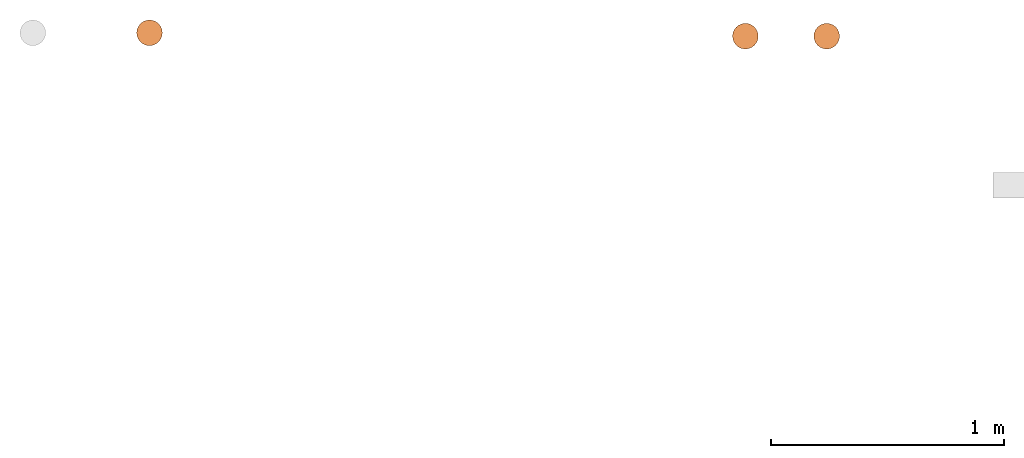
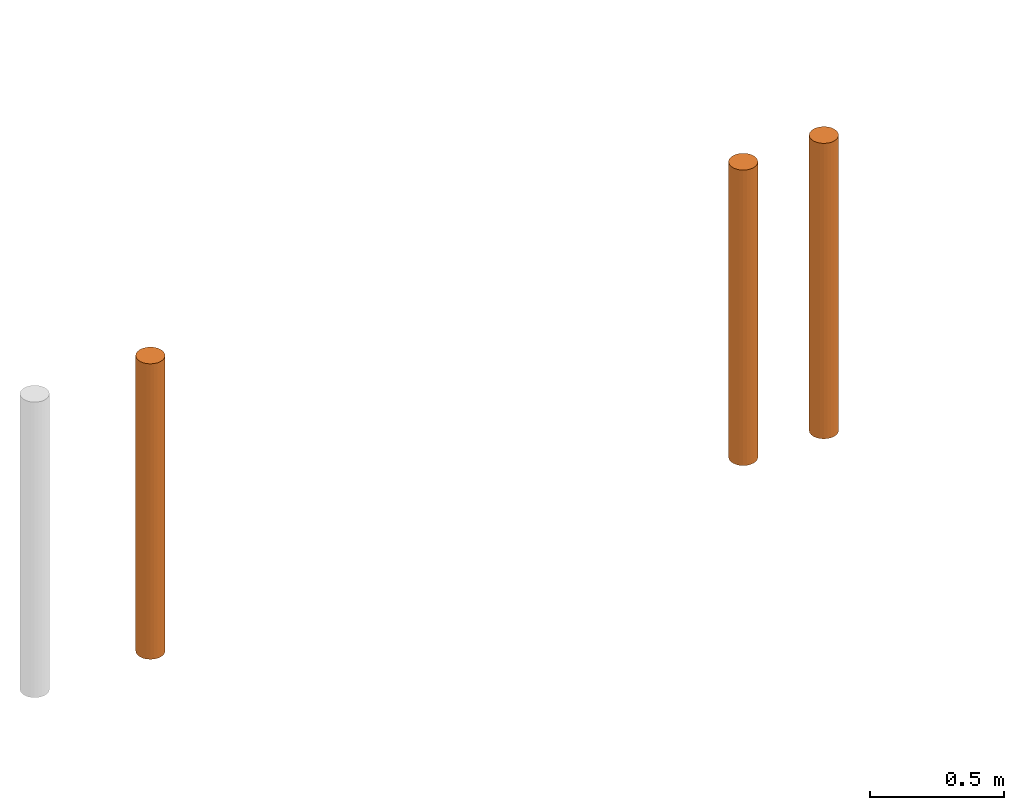
# One storey, part 3 of 5: 3 proxies.
"""IFC2X3 building model written with IfcOpenShell, lengths in metres."""

from ifc_helpers import new_model, entity, si_unit, converted_unit, frame, origin, place, context, subcontext, project, spatial, faceted_brep, material, element, save


model = new_model("IFC2X3")

# Units and contexts
model_context = context("Model", 3, precision=1e-05, world=origin())
body_context = subcontext(model_context, "Body", "Model", "MODEL_VIEW")
ifc_project = project(units=[si_unit("LENGTHUNIT", "METRE"), si_unit("AREAUNIT", "SQUARE_METRE"), si_unit("VOLUMEUNIT", "CUBIC_METRE"), converted_unit("PLANEANGLEUNIT", "DEGREE", entity("IfcPlaneAngleMeasure", 0.0174532925199433), si_unit("PLANEANGLEUNIT", "RADIAN"), dimensions=[0, 0, 0, 0, 0, 0, 0])], contexts=[model_context])

# Site, building, storey
site_placement = place(None, frame((2.0, 7.0, 6.0)))
site = spatial("IfcSite", under=ifc_project, at=site_placement, CompositionType="ELEMENT")
building_placement = place(site_placement, origin())
building = spatial("IfcBuilding", under=site, at=building_placement, Name="de", CompositionType="ELEMENT")
storey_placement = place(building_placement, frame((0.0, 0.0, 4.0)))
storey = spatial("IfcBuildingStorey", under=building, at=storey_placement, CompositionType="ELEMENT", Elevation=4.0)

# Proxies
ifc_material_1 = material()
proxy_1_placement = place(storey_placement, frame((-5.162044050769238, 7.713461170358987, 2.696227106227107)))
element("IfcBuildingElementProxy", 1, at=proxy_1_placement, inside=storey, material=ifc_material_1, context=body_context, shape_type="Brep", body=[
    faceted_brep([(0.05499999999999999, 0.1099999999999995, 9.094947017729283e-16), (0.05499999999999999, 0.1099999999999996, 1.35), (0.04076495251936132, 0.1081259204458984, 1.35), (0.04076495251936132, 0.1081259204458982, 9.094947017729283e-16), (0.04076495251936132, 0.1081259204458982, 9.094947017729283e-16), (0.04076495251936132, 0.1081259204458984, 1.35), (0.02749999999999994, 0.1026313972081437, 1.35), (0.02749999999999994, 0.1026313972081436, 9.094947017729283e-16), (0.02749999999999994, 0.1026313972081436, 9.094947017729283e-16), (0.02749999999999994, 0.1026313972081437, 1.35), (0.01610912703473984, 0.09389087296525969, 1.35), (0.01610912703473984, 0.09389087296525954, 9.094947017729283e-16), (0.01610912703473984, 0.09389087296525954, 9.094947017729283e-16), (0.01610912703473984, 0.09389087296525969, 1.35), (0.007368602791855849, 0.08249999999999959, 1.35), (0.007368602791855849, 0.08249999999999943, 9.094947017729283e-16), (0.007368602791855849, 0.08249999999999943, 9.094947017729283e-16), (0.007368602791855849, 0.08249999999999959, 1.35), (0.001874079554101236, 0.06923504748063825, 1.35), (0.001874079554101236, 0.06923504748063809, 9.094947017729283e-16), (0.001874079554101236, 0.06923504748063809, 9.094947017729283e-16), (0.001874079554101236, 0.06923504748063825, 1.35), (0.0, 0.05499999999999957, 1.35), (0.0, 0.0549999999999994, 9.094947017729283e-16), (0.0, 0.0549999999999994, 9.094947017729283e-16), (0.0, 0.05499999999999957, 1.35), (0.001874079554101257, 0.04076495251936095, 1.35), (0.001874079554101257, 0.04076495251936078, 9.094947017729283e-16), (0.001874079554101257, 0.04076495251936078, 9.094947017729283e-16), (0.001874079554101257, 0.04076495251936095, 1.35), (0.007368602791855913, 0.02749999999999957, 1.35), (0.007368602791855913, 0.0274999999999994, 9.094947017729283e-16), (0.007368602791855913, 0.0274999999999994, 9.094947017729283e-16), (0.007368602791855913, 0.02749999999999957, 1.35), (0.01610912703473991, 0.01610912703473949, 1.35), (0.01610912703473991, 0.01610912703473933, 9.094947017729283e-16), (0.01610912703473991, 0.01610912703473933, 9.094947017729283e-16), (0.01610912703473991, 0.01610912703473949, 1.35), (0.02750000000000004, 0.00736860279185548, 1.35), (0.02750000000000004, 0.007368602791855317, 9.094947017729283e-16), (0.02750000000000004, 0.007368602791855317, 9.094947017729283e-16), (0.02750000000000004, 0.00736860279185548, 1.35), (0.0407649525193614, 0.001874079554100867, 1.35), (0.0407649525193614, 0.001874079554100696, 9.094947017729283e-16), (0.0407649525193614, 0.001874079554100696, 9.094947017729283e-16), (0.0407649525193614, 0.001874079554100867, 1.35), (0.05500000000000003, -3.694822225952521e-16, 1.35), (0.05500000000000003, -5.400124791776761e-16, 9.094947017729283e-16), (0.05500000000000003, -5.400124791776761e-16, 9.094947017729283e-16), (0.05500000000000003, -3.694822225952521e-16, 1.35), (0.06923504748063866, 0.001874079554100881, 1.35), (0.06923504748063866, 0.001874079554100703, 9.094947017729283e-16), (0.06923504748063866, 0.001874079554100703, 9.094947017729283e-16), (0.06923504748063866, 0.001874079554100881, 1.35), (0.08250000000000002, 0.007368602791855515, 1.35), (0.08250000000000002, 0.007368602791855352, 9.094947017729283e-16), (0.08250000000000002, 0.007368602791855352, 9.094947017729283e-16), (0.08250000000000002, 0.007368602791855515, 1.35), (0.09389087296526015, 0.01610912703473954, 1.35), (0.09389087296526015, 0.01610912703473937, 9.094947017729283e-16), (0.09389087296526015, 0.01610912703473937, 9.094947017729283e-16), (0.09389087296526015, 0.01610912703473954, 1.35), (0.1026313972081441, 0.02749999999999964, 1.35), (0.1026313972081441, 0.02749999999999948, 9.094947017729283e-16), (0.1026313972081441, 0.02749999999999948, 9.094947017729283e-16), (0.1026313972081441, 0.02749999999999964, 1.35), (0.1081259204458988, 0.04076495251936101, 1.35), (0.1081259204458988, 0.04076495251936084, 9.094947017729283e-16), (0.1081259204458988, 0.04076495251936084, 9.094947017729283e-16), (0.1081259204458988, 0.04076495251936101, 1.35), (0.11, 0.05499999999999979, 1.35), (0.11, 0.05499999999999954, 9.094947017729283e-16), (0.11, 0.05499999999999954, 9.094947017729283e-16), (0.11, 0.05499999999999979, 1.35), (0.1081259204458988, 0.06923504748063827, 1.35), (0.1081259204458988, 0.06923504748063812, 9.094947017729283e-16), (0.1081259204458988, 0.06923504748063812, 9.094947017729283e-16), (0.1081259204458988, 0.06923504748063827, 1.35), (0.1026313972081441, 0.08249999999999963, 1.35), (0.1026313972081441, 0.08249999999999946, 9.094947017729283e-16), (0.1026313972081441, 0.08249999999999946, 9.094947017729283e-16), (0.1026313972081441, 0.08249999999999963, 1.35), (0.09389087296526012, 0.09389087296525975, 1.35), (0.09389087296526012, 0.09389087296525958, 9.094947017729283e-16), (0.09389087296526012, 0.09389087296525958, 9.094947017729283e-16), (0.09389087296526012, 0.09389087296525975, 1.35), (0.0825, 0.1026313972081438, 1.35), (0.0825, 0.1026313972081436, 9.094947017729283e-16), (0.0825, 0.1026313972081436, 9.094947017729283e-16), (0.0825, 0.1026313972081438, 1.35), (0.06923504748063865, 0.1081259204458984, 1.35), (0.06923504748063865, 0.1081259204458982, 9.094947017729283e-16), (0.06923504748063865, 0.1081259204458982, 9.094947017729283e-16), (0.06923504748063865, 0.1081259204458984, 1.35), (0.05499999999999999, 0.1099999999999996, 1.35), (0.05499999999999999, 0.1099999999999995, 9.094947017729283e-16), (0.11, 0.05499999999999954, 9.094947017729283e-16), (0.1081259204458988, 0.06923504748063812, 9.094947017729283e-16), (0.1026313972081441, 0.08249999999999946, 9.094947017729283e-16), (0.09389087296526012, 0.09389087296525958, 9.094947017729283e-16), (0.0825, 0.1026313972081436, 9.094947017729283e-16), (0.06923504748063865, 0.1081259204458982, 9.094947017729283e-16), (0.05499999999999999, 0.1099999999999995, 9.094947017729283e-16), (0.04076495251936132, 0.1081259204458982, 9.094947017729283e-16), (0.02749999999999994, 0.1026313972081436, 9.094947017729283e-16), (0.01610912703473984, 0.09389087296525954, 9.094947017729283e-16), (0.007368602791855849, 0.08249999999999943, 9.094947017729283e-16), (0.001874079554101236, 0.06923504748063809, 9.094947017729283e-16), (0.0, 0.0549999999999994, 9.094947017729283e-16), (0.001874079554101257, 0.04076495251936078, 9.094947017729283e-16), (0.007368602791855913, 0.0274999999999994, 9.094947017729283e-16), (0.01610912703473991, 0.01610912703473933, 9.094947017729283e-16), (0.02750000000000004, 0.007368602791855317, 9.094947017729283e-16), (0.0407649525193614, 0.001874079554100696, 9.094947017729283e-16), (0.05500000000000003, -5.400124791776761e-16, 9.094947017729283e-16), (0.06923504748063866, 0.001874079554100703, 9.094947017729283e-16), (0.08250000000000002, 0.007368602791855352, 9.094947017729283e-16), (0.09389087296526015, 0.01610912703473937, 9.094947017729283e-16), (0.1026313972081441, 0.02749999999999948, 9.094947017729283e-16), (0.1081259204458988, 0.04076495251936084, 9.094947017729283e-16), (0.11, 0.05499999999999979, 1.35), (0.1081259204458988, 0.04076495251936101, 1.35), (0.1026313972081441, 0.02749999999999964, 1.35), (0.09389087296526015, 0.01610912703473954, 1.35), (0.08250000000000002, 0.007368602791855515, 1.35), (0.06923504748063866, 0.001874079554100881, 1.35), (0.05500000000000003, -3.694822225952521e-16, 1.35), (0.0407649525193614, 0.001874079554100867, 1.35), (0.02750000000000004, 0.00736860279185548, 1.35), (0.01610912703473991, 0.01610912703473949, 1.35), (0.007368602791855913, 0.02749999999999957, 1.35), (0.001874079554101257, 0.04076495251936095, 1.35), (0.0, 0.05499999999999957, 1.35), (0.001874079554101236, 0.06923504748063825, 1.35), (0.007368602791855849, 0.08249999999999959, 1.35), (0.01610912703473984, 0.09389087296525969, 1.35), (0.02749999999999994, 0.1026313972081437, 1.35), (0.04076495251936132, 0.1081259204458984, 1.35), (0.05499999999999999, 0.1099999999999996, 1.35), (0.06923504748063865, 0.1081259204458984, 1.35), (0.0825, 0.1026313972081438, 1.35), (0.09389087296526012, 0.09389087296525975, 1.35), (0.1026313972081441, 0.08249999999999963, 1.35), (0.1081259204458988, 0.06923504748063827, 1.35)], [[[0, 1, 2, 3]], [[4, 5, 6, 7]], [[8, 9, 10, 11]], [[12, 13, 14, 15]], [[16, 17, 18, 19]], [[20, 21, 22, 23]], [[24, 25, 26, 27]], [[28, 29, 30, 31]], [[32, 33, 34, 35]], [[36, 37, 38, 39]], [[40, 41, 42, 43]], [[44, 45, 46, 47]], [[48, 49, 50, 51]], [[52, 53, 54, 55]], [[56, 57, 58, 59]], [[60, 61, 62, 63]], [[64, 65, 66, 67]], [[68, 69, 70, 71]], [[72, 73, 74, 75]], [[76, 77, 78, 79]], [[80, 81, 82, 83]], [[84, 85, 86, 87]], [[88, 89, 90, 91]], [[92, 93, 94, 95]], [[96, 97, 98, 99, 100, 101, 102, 103, 104, 105, 106, 107, 108, 109, 110, 111, 112, 113, 114, 115, 116, 117, 118, 119]], [[120, 121, 122, 123, 124, 125, 126, 127, 128, 129, 130, 131, 132, 133, 134, 135, 136, 137, 138, 139, 140, 141, 142, 143]]], orient=[[False], [False], [False], [False], [False], [False], [False], [False], [False], [False], [False], [False], [False], [False], [False], [False], [False], [False], [False], [False], [False], [False], [False], [False], [False], [False]]),
])
ifc_material_2 = material()
proxy_2_placement = place(storey_placement, frame((-2.608355565197468, 7.699048402584865, 2.696227106227107)))
element("IfcBuildingElementProxy", 2, at=proxy_2_placement, inside=storey, material=ifc_material_2, context=body_context, shape_type="Brep", body=[
    faceted_brep([(0.05499999999999999, 0.1100000000000004, 9.094947017729283e-16), (0.05499999999999999, 0.1100000000000005, 1.35), (0.04076495251936132, 0.1081259204458993, 1.35), (0.04076495251936132, 0.1081259204458991, 9.094947017729283e-16), (0.04076495251936132, 0.1081259204458991, 9.094947017729283e-16), (0.04076495251936132, 0.1081259204458993, 1.35), (0.02749999999999994, 0.1026313972081446, 1.35), (0.02749999999999994, 0.1026313972081445, 9.094947017729283e-16), (0.02749999999999994, 0.1026313972081445, 9.094947017729283e-16), (0.02749999999999994, 0.1026313972081446, 1.35), (0.01610912703473984, 0.0938908729652606, 1.35), (0.01610912703473984, 0.09389087296526044, 9.094947017729283e-16), (0.01610912703473984, 0.09389087296526044, 9.094947017729283e-16), (0.01610912703473984, 0.0938908729652606, 1.35), (0.007368602791855849, 0.0825000000000005, 1.35), (0.007368602791855849, 0.08250000000000034, 9.094947017729283e-16), (0.007368602791855849, 0.08250000000000034, 9.094947017729283e-16), (0.007368602791855849, 0.0825000000000005, 1.35), (0.001874079554101236, 0.06923504748063916, 1.35), (0.001874079554101236, 0.069235047480639, 9.094947017729283e-16), (0.001874079554101236, 0.069235047480639, 9.094947017729283e-16), (0.001874079554101236, 0.06923504748063916, 1.35), (0.0, 0.05500000000000048, 1.35), (0.0, 0.05500000000000031, 9.094947017729283e-16), (0.0, 0.05500000000000031, 9.094947017729283e-16), (0.0, 0.05500000000000048, 1.35), (0.001874079554101257, 0.04076495251936186, 1.35), (0.001874079554101257, 0.04076495251936169, 9.094947017729283e-16), (0.001874079554101257, 0.04076495251936169, 9.094947017729283e-16), (0.001874079554101257, 0.04076495251936186, 1.35), (0.007368602791855913, 0.02750000000000048, 1.35), (0.007368602791855913, 0.02750000000000031, 9.094947017729283e-16), (0.007368602791855913, 0.02750000000000031, 9.094947017729283e-16), (0.007368602791855913, 0.02750000000000048, 1.35), (0.01610912703473991, 0.0161091270347404, 1.35), (0.01610912703473991, 0.01610912703474024, 9.094947017729283e-16), (0.01610912703473991, 0.01610912703474024, 9.094947017729283e-16), (0.01610912703473991, 0.0161091270347404, 1.35), (0.02750000000000004, 0.00736860279185639, 1.35), (0.02750000000000004, 0.007368602791856227, 9.094947017729283e-16), (0.02750000000000004, 0.007368602791856227, 9.094947017729283e-16), (0.02750000000000004, 0.00736860279185639, 1.35), (0.0407649525193614, 0.001874079554101776, 1.35), (0.0407649525193614, 0.001874079554101606, 9.094947017729283e-16), (0.0407649525193614, 0.001874079554101606, 9.094947017729283e-16), (0.0407649525193614, 0.001874079554101776, 1.35), (0.05500000000000003, 5.400124791776761e-16, 1.35), (0.05500000000000003, 3.694822225952521e-16, 9.094947017729283e-16), (0.05500000000000003, 3.694822225952521e-16, 9.094947017729283e-16), (0.05500000000000003, 5.400124791776761e-16, 1.35), (0.06923504748063866, 0.00187407955410179, 1.35), (0.06923504748063866, 0.001874079554101613, 9.094947017729283e-16), (0.06923504748063866, 0.001874079554101613, 9.094947017729283e-16), (0.06923504748063866, 0.00187407955410179, 1.35), (0.08250000000000002, 0.007368602791856425, 1.35), (0.08250000000000002, 0.007368602791856262, 9.094947017729283e-16), (0.08250000000000002, 0.007368602791856262, 9.094947017729283e-16), (0.08250000000000002, 0.007368602791856425, 1.35), (0.09389087296526015, 0.01610912703474045, 1.35), (0.09389087296526015, 0.01610912703474028, 9.094947017729283e-16), (0.09389087296526015, 0.01610912703474028, 9.094947017729283e-16), (0.09389087296526015, 0.01610912703474045, 1.35), (0.1026313972081441, 0.02750000000000055, 1.35), (0.1026313972081441, 0.02750000000000039, 9.094947017729283e-16), (0.1026313972081441, 0.02750000000000039, 9.094947017729283e-16), (0.1026313972081441, 0.02750000000000055, 1.35), (0.1081259204458988, 0.04076495251936192, 1.35), (0.1081259204458988, 0.04076495251936175, 9.094947017729283e-16), (0.1081259204458988, 0.04076495251936175, 9.094947017729283e-16), (0.1081259204458988, 0.04076495251936192, 1.35), (0.11, 0.05500000000000071, 1.35), (0.11, 0.05500000000000045, 9.094947017729283e-16), (0.11, 0.05500000000000045, 9.094947017729283e-16), (0.11, 0.05500000000000071, 1.35), (0.1081259204458988, 0.06923504748063919, 1.35), (0.1081259204458988, 0.06923504748063902, 9.094947017729283e-16), (0.1081259204458988, 0.06923504748063902, 9.094947017729283e-16), (0.1081259204458988, 0.06923504748063919, 1.35), (0.1026313972081441, 0.08250000000000055, 1.35), (0.1026313972081441, 0.08250000000000036, 9.094947017729283e-16), (0.1026313972081441, 0.08250000000000036, 9.094947017729283e-16), (0.1026313972081441, 0.08250000000000055, 1.35), (0.09389087296526012, 0.09389087296526066, 1.35), (0.09389087296526012, 0.09389087296526048, 9.094947017729283e-16), (0.09389087296526012, 0.09389087296526048, 9.094947017729283e-16), (0.09389087296526012, 0.09389087296526066, 1.35), (0.0825, 0.1026313972081447, 1.35), (0.0825, 0.1026313972081445, 9.094947017729283e-16), (0.0825, 0.1026313972081445, 9.094947017729283e-16), (0.0825, 0.1026313972081447, 1.35), (0.06923504748063865, 0.1081259204458993, 1.35), (0.06923504748063865, 0.1081259204458991, 9.094947017729283e-16), (0.06923504748063865, 0.1081259204458991, 9.094947017729283e-16), (0.06923504748063865, 0.1081259204458993, 1.35), (0.05499999999999999, 0.1100000000000005, 1.35), (0.05499999999999999, 0.1100000000000004, 9.094947017729283e-16), (0.11, 0.05500000000000045, 9.094947017729283e-16), (0.1081259204458988, 0.06923504748063902, 9.094947017729283e-16), (0.1026313972081441, 0.08250000000000036, 9.094947017729283e-16), (0.09389087296526012, 0.09389087296526048, 9.094947017729283e-16), (0.0825, 0.1026313972081445, 9.094947017729283e-16), (0.06923504748063865, 0.1081259204458991, 9.094947017729283e-16), (0.05499999999999999, 0.1100000000000004, 9.094947017729283e-16), (0.04076495251936132, 0.1081259204458991, 9.094947017729283e-16), (0.02749999999999994, 0.1026313972081445, 9.094947017729283e-16), (0.01610912703473984, 0.09389087296526044, 9.094947017729283e-16), (0.007368602791855849, 0.08250000000000034, 9.094947017729283e-16), (0.001874079554101236, 0.069235047480639, 9.094947017729283e-16), (0.0, 0.05500000000000031, 9.094947017729283e-16), (0.001874079554101257, 0.04076495251936169, 9.094947017729283e-16), (0.007368602791855913, 0.02750000000000031, 9.094947017729283e-16), (0.01610912703473991, 0.01610912703474024, 9.094947017729283e-16), (0.02750000000000004, 0.007368602791856227, 9.094947017729283e-16), (0.0407649525193614, 0.001874079554101606, 9.094947017729283e-16), (0.05500000000000003, 3.694822225952521e-16, 9.094947017729283e-16), (0.06923504748063866, 0.001874079554101613, 9.094947017729283e-16), (0.08250000000000002, 0.007368602791856262, 9.094947017729283e-16), (0.09389087296526015, 0.01610912703474028, 9.094947017729283e-16), (0.1026313972081441, 0.02750000000000039, 9.094947017729283e-16), (0.1081259204458988, 0.04076495251936175, 9.094947017729283e-16), (0.11, 0.05500000000000071, 1.35), (0.1081259204458988, 0.04076495251936192, 1.35), (0.1026313972081441, 0.02750000000000055, 1.35), (0.09389087296526015, 0.01610912703474045, 1.35), (0.08250000000000002, 0.007368602791856425, 1.35), (0.06923504748063866, 0.00187407955410179, 1.35), (0.05500000000000003, 5.400124791776761e-16, 1.35), (0.0407649525193614, 0.001874079554101776, 1.35), (0.02750000000000004, 0.00736860279185639, 1.35), (0.01610912703473991, 0.0161091270347404, 1.35), (0.007368602791855913, 0.02750000000000048, 1.35), (0.001874079554101257, 0.04076495251936186, 1.35), (0.0, 0.05500000000000048, 1.35), (0.001874079554101236, 0.06923504748063916, 1.35), (0.007368602791855849, 0.0825000000000005, 1.35), (0.01610912703473984, 0.0938908729652606, 1.35), (0.02749999999999994, 0.1026313972081446, 1.35), (0.04076495251936132, 0.1081259204458993, 1.35), (0.05499999999999999, 0.1100000000000005, 1.35), (0.06923504748063865, 0.1081259204458993, 1.35), (0.0825, 0.1026313972081447, 1.35), (0.09389087296526012, 0.09389087296526066, 1.35), (0.1026313972081441, 0.08250000000000055, 1.35), (0.1081259204458988, 0.06923504748063919, 1.35)], [[[0, 1, 2, 3]], [[4, 5, 6, 7]], [[8, 9, 10, 11]], [[12, 13, 14, 15]], [[16, 17, 18, 19]], [[20, 21, 22, 23]], [[24, 25, 26, 27]], [[28, 29, 30, 31]], [[32, 33, 34, 35]], [[36, 37, 38, 39]], [[40, 41, 42, 43]], [[44, 45, 46, 47]], [[48, 49, 50, 51]], [[52, 53, 54, 55]], [[56, 57, 58, 59]], [[60, 61, 62, 63]], [[64, 65, 66, 67]], [[68, 69, 70, 71]], [[72, 73, 74, 75]], [[76, 77, 78, 79]], [[80, 81, 82, 83]], [[84, 85, 86, 87]], [[88, 89, 90, 91]], [[92, 93, 94, 95]], [[96, 97, 98, 99, 100, 101, 102, 103, 104, 105, 106, 107, 108, 109, 110, 111, 112, 113, 114, 115, 116, 117, 118, 119]], [[120, 121, 122, 123, 124, 125, 126, 127, 128, 129, 130, 131, 132, 133, 134, 135, 136, 137, 138, 139, 140, 141, 142, 143]]], orient=[[False], [False], [False], [False], [False], [False], [False], [False], [False], [False], [False], [False], [False], [False], [False], [False], [False], [False], [False], [False], [False], [False], [False], [False], [False], [False]]),
])
ifc_material_3 = material()
proxy_3_placement = place(storey_placement, frame((-2.259882605736549, 7.699048402584865, 2.696227106227107)))
element("IfcBuildingElementProxy", 3, at=proxy_3_placement, inside=storey, material=ifc_material_3, context=body_context, shape_type="Brep", body=[
    faceted_brep([(0.05499999999999999, 0.1100000000000004, 9.094947017729283e-16), (0.05499999999999999, 0.1100000000000005, 1.35), (0.04076495251936132, 0.1081259204458993, 1.35), (0.04076495251936132, 0.1081259204458991, 9.094947017729283e-16), (0.04076495251936132, 0.1081259204458991, 9.094947017729283e-16), (0.04076495251936132, 0.1081259204458993, 1.35), (0.02749999999999994, 0.1026313972081446, 1.35), (0.02749999999999994, 0.1026313972081445, 9.094947017729283e-16), (0.02749999999999994, 0.1026313972081445, 9.094947017729283e-16), (0.02749999999999994, 0.1026313972081446, 1.35), (0.01610912703473984, 0.0938908729652606, 1.35), (0.01610912703473984, 0.09389087296526044, 9.094947017729283e-16), (0.01610912703473984, 0.09389087296526044, 9.094947017729283e-16), (0.01610912703473984, 0.0938908729652606, 1.35), (0.007368602791855849, 0.0825000000000005, 1.35), (0.007368602791855849, 0.08250000000000034, 9.094947017729283e-16), (0.007368602791855849, 0.08250000000000034, 9.094947017729283e-16), (0.007368602791855849, 0.0825000000000005, 1.35), (0.001874079554101236, 0.06923504748063916, 1.35), (0.001874079554101236, 0.069235047480639, 9.094947017729283e-16), (0.001874079554101236, 0.069235047480639, 9.094947017729283e-16), (0.001874079554101236, 0.06923504748063916, 1.35), (0.0, 0.05500000000000048, 1.35), (0.0, 0.05500000000000031, 9.094947017729283e-16), (0.0, 0.05500000000000031, 9.094947017729283e-16), (0.0, 0.05500000000000048, 1.35), (0.001874079554101257, 0.04076495251936186, 1.35), (0.001874079554101257, 0.04076495251936169, 9.094947017729283e-16), (0.001874079554101257, 0.04076495251936169, 9.094947017729283e-16), (0.001874079554101257, 0.04076495251936186, 1.35), (0.007368602791855913, 0.02750000000000048, 1.35), (0.007368602791855913, 0.02750000000000031, 9.094947017729283e-16), (0.007368602791855913, 0.02750000000000031, 9.094947017729283e-16), (0.007368602791855913, 0.02750000000000048, 1.35), (0.01610912703473991, 0.0161091270347404, 1.35), (0.01610912703473991, 0.01610912703474024, 9.094947017729283e-16), (0.01610912703473991, 0.01610912703474024, 9.094947017729283e-16), (0.01610912703473991, 0.0161091270347404, 1.35), (0.02750000000000004, 0.00736860279185639, 1.35), (0.02750000000000004, 0.007368602791856227, 9.094947017729283e-16), (0.02750000000000004, 0.007368602791856227, 9.094947017729283e-16), (0.02750000000000004, 0.00736860279185639, 1.35), (0.0407649525193614, 0.001874079554101776, 1.35), (0.0407649525193614, 0.001874079554101606, 9.094947017729283e-16), (0.0407649525193614, 0.001874079554101606, 9.094947017729283e-16), (0.0407649525193614, 0.001874079554101776, 1.35), (0.05500000000000003, 5.400124791776761e-16, 1.35), (0.05500000000000003, 3.694822225952521e-16, 9.094947017729283e-16), (0.05500000000000003, 3.694822225952521e-16, 9.094947017729283e-16), (0.05500000000000003, 5.400124791776761e-16, 1.35), (0.06923504748063866, 0.00187407955410179, 1.35), (0.06923504748063866, 0.001874079554101613, 9.094947017729283e-16), (0.06923504748063866, 0.001874079554101613, 9.094947017729283e-16), (0.06923504748063866, 0.00187407955410179, 1.35), (0.08250000000000002, 0.007368602791856425, 1.35), (0.08250000000000002, 0.007368602791856262, 9.094947017729283e-16), (0.08250000000000002, 0.007368602791856262, 9.094947017729283e-16), (0.08250000000000002, 0.007368602791856425, 1.35), (0.09389087296526015, 0.01610912703474045, 1.35), (0.09389087296526015, 0.01610912703474028, 9.094947017729283e-16), (0.09389087296526015, 0.01610912703474028, 9.094947017729283e-16), (0.09389087296526015, 0.01610912703474045, 1.35), (0.1026313972081441, 0.02750000000000055, 1.35), (0.1026313972081441, 0.02750000000000039, 9.094947017729283e-16), (0.1026313972081441, 0.02750000000000039, 9.094947017729283e-16), (0.1026313972081441, 0.02750000000000055, 1.35), (0.1081259204458988, 0.04076495251936192, 1.35), (0.1081259204458988, 0.04076495251936175, 9.094947017729283e-16), (0.1081259204458988, 0.04076495251936175, 9.094947017729283e-16), (0.1081259204458988, 0.04076495251936192, 1.35), (0.11, 0.05500000000000071, 1.35), (0.11, 0.05500000000000045, 9.094947017729283e-16), (0.11, 0.05500000000000045, 9.094947017729283e-16), (0.11, 0.05500000000000071, 1.35), (0.1081259204458988, 0.06923504748063919, 1.35), (0.1081259204458988, 0.06923504748063902, 9.094947017729283e-16), (0.1081259204458988, 0.06923504748063902, 9.094947017729283e-16), (0.1081259204458988, 0.06923504748063919, 1.35), (0.1026313972081441, 0.08250000000000055, 1.35), (0.1026313972081441, 0.08250000000000036, 9.094947017729283e-16), (0.1026313972081441, 0.08250000000000036, 9.094947017729283e-16), (0.1026313972081441, 0.08250000000000055, 1.35), (0.09389087296526012, 0.09389087296526066, 1.35), (0.09389087296526012, 0.09389087296526048, 9.094947017729283e-16), (0.09389087296526012, 0.09389087296526048, 9.094947017729283e-16), (0.09389087296526012, 0.09389087296526066, 1.35), (0.0825, 0.1026313972081447, 1.35), (0.0825, 0.1026313972081445, 9.094947017729283e-16), (0.0825, 0.1026313972081445, 9.094947017729283e-16), (0.0825, 0.1026313972081447, 1.35), (0.06923504748063865, 0.1081259204458993, 1.35), (0.06923504748063865, 0.1081259204458991, 9.094947017729283e-16), (0.06923504748063865, 0.1081259204458991, 9.094947017729283e-16), (0.06923504748063865, 0.1081259204458993, 1.35), (0.05499999999999999, 0.1100000000000005, 1.35), (0.05499999999999999, 0.1100000000000004, 9.094947017729283e-16), (0.11, 0.05500000000000045, 9.094947017729283e-16), (0.1081259204458988, 0.06923504748063902, 9.094947017729283e-16), (0.1026313972081441, 0.08250000000000036, 9.094947017729283e-16), (0.09389087296526012, 0.09389087296526048, 9.094947017729283e-16), (0.0825, 0.1026313972081445, 9.094947017729283e-16), (0.06923504748063865, 0.1081259204458991, 9.094947017729283e-16), (0.05499999999999999, 0.1100000000000004, 9.094947017729283e-16), (0.04076495251936132, 0.1081259204458991, 9.094947017729283e-16), (0.02749999999999994, 0.1026313972081445, 9.094947017729283e-16), (0.01610912703473984, 0.09389087296526044, 9.094947017729283e-16), (0.007368602791855849, 0.08250000000000034, 9.094947017729283e-16), (0.001874079554101236, 0.069235047480639, 9.094947017729283e-16), (0.0, 0.05500000000000031, 9.094947017729283e-16), (0.001874079554101257, 0.04076495251936169, 9.094947017729283e-16), (0.007368602791855913, 0.02750000000000031, 9.094947017729283e-16), (0.01610912703473991, 0.01610912703474024, 9.094947017729283e-16), (0.02750000000000004, 0.007368602791856227, 9.094947017729283e-16), (0.0407649525193614, 0.001874079554101606, 9.094947017729283e-16), (0.05500000000000003, 3.694822225952521e-16, 9.094947017729283e-16), (0.06923504748063866, 0.001874079554101613, 9.094947017729283e-16), (0.08250000000000002, 0.007368602791856262, 9.094947017729283e-16), (0.09389087296526015, 0.01610912703474028, 9.094947017729283e-16), (0.1026313972081441, 0.02750000000000039, 9.094947017729283e-16), (0.1081259204458988, 0.04076495251936175, 9.094947017729283e-16), (0.11, 0.05500000000000071, 1.35), (0.1081259204458988, 0.04076495251936192, 1.35), (0.1026313972081441, 0.02750000000000055, 1.35), (0.09389087296526015, 0.01610912703474045, 1.35), (0.08250000000000002, 0.007368602791856425, 1.35), (0.06923504748063866, 0.00187407955410179, 1.35), (0.05500000000000003, 5.400124791776761e-16, 1.35), (0.0407649525193614, 0.001874079554101776, 1.35), (0.02750000000000004, 0.00736860279185639, 1.35), (0.01610912703473991, 0.0161091270347404, 1.35), (0.007368602791855913, 0.02750000000000048, 1.35), (0.001874079554101257, 0.04076495251936186, 1.35), (0.0, 0.05500000000000048, 1.35), (0.001874079554101236, 0.06923504748063916, 1.35), (0.007368602791855849, 0.0825000000000005, 1.35), (0.01610912703473984, 0.0938908729652606, 1.35), (0.02749999999999994, 0.1026313972081446, 1.35), (0.04076495251936132, 0.1081259204458993, 1.35), (0.05499999999999999, 0.1100000000000005, 1.35), (0.06923504748063865, 0.1081259204458993, 1.35), (0.0825, 0.1026313972081447, 1.35), (0.09389087296526012, 0.09389087296526066, 1.35), (0.1026313972081441, 0.08250000000000055, 1.35), (0.1081259204458988, 0.06923504748063919, 1.35)], [[[0, 1, 2, 3]], [[4, 5, 6, 7]], [[8, 9, 10, 11]], [[12, 13, 14, 15]], [[16, 17, 18, 19]], [[20, 21, 22, 23]], [[24, 25, 26, 27]], [[28, 29, 30, 31]], [[32, 33, 34, 35]], [[36, 37, 38, 39]], [[40, 41, 42, 43]], [[44, 45, 46, 47]], [[48, 49, 50, 51]], [[52, 53, 54, 55]], [[56, 57, 58, 59]], [[60, 61, 62, 63]], [[64, 65, 66, 67]], [[68, 69, 70, 71]], [[72, 73, 74, 75]], [[76, 77, 78, 79]], [[80, 81, 82, 83]], [[84, 85, 86, 87]], [[88, 89, 90, 91]], [[92, 93, 94, 95]], [[96, 97, 98, 99, 100, 101, 102, 103, 104, 105, 106, 107, 108, 109, 110, 111, 112, 113, 114, 115, 116, 117, 118, 119]], [[120, 121, 122, 123, 124, 125, 126, 127, 128, 129, 130, 131, 132, 133, 134, 135, 136, 137, 138, 139, 140, 141, 142, 143]]], orient=[[False], [False], [False], [False], [False], [False], [False], [False], [False], [False], [False], [False], [False], [False], [False], [False], [False], [False], [False], [False], [False], [False], [False], [False], [False], [False]]),
])

save(model, "model.ifc")
